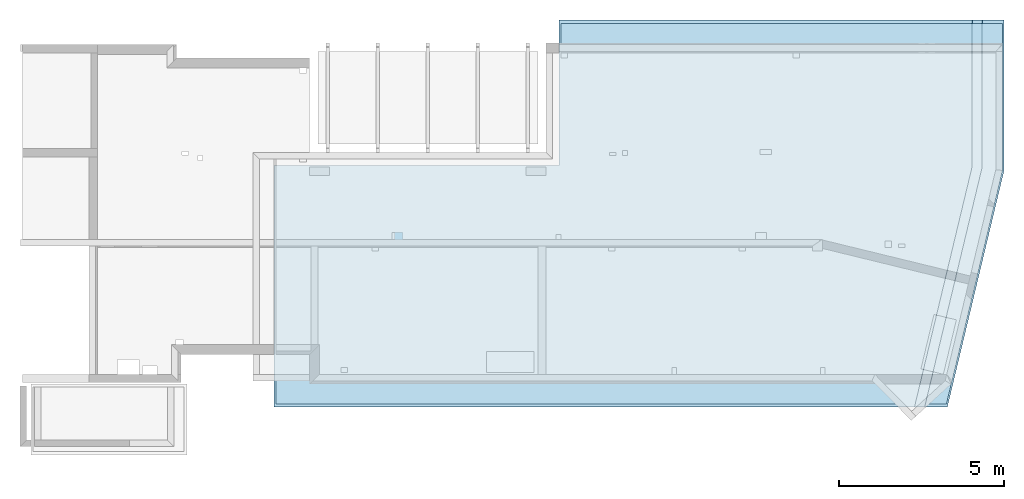
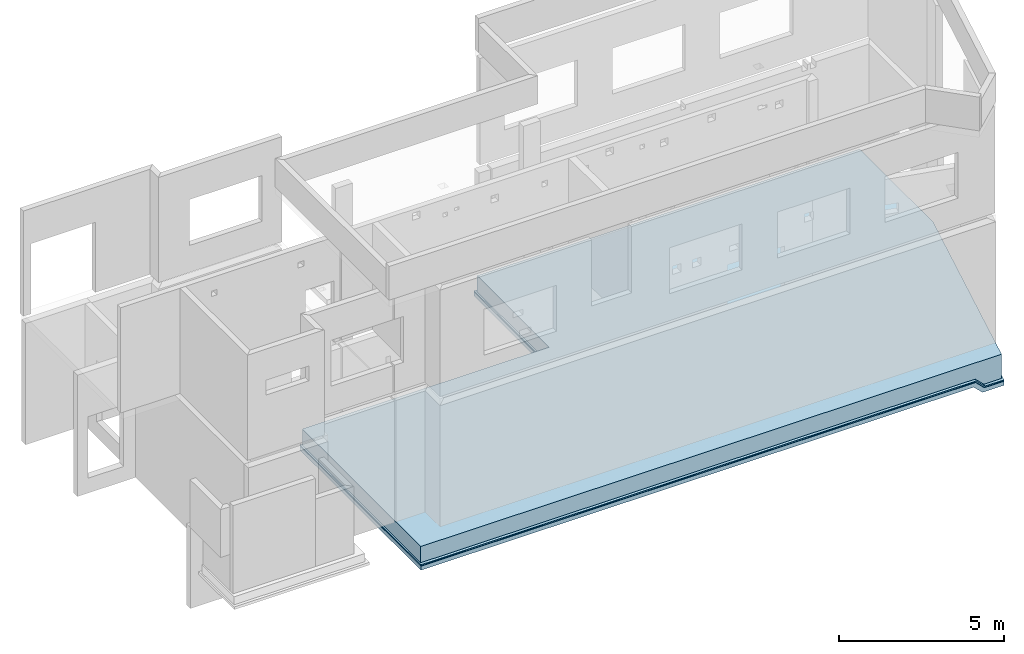
# One storey, part 7 of 7: 3 slabs.
"""IFC2X3 building model written with IfcOpenShell, lengths in millimetres."""

import ifcopenshell
import ifcopenshell.guid

model = None  # the IFC model being written
_history = None  # IfcOwnerHistory: only IFC2X3 demands one
_inside = {}  # id of a spatial element -> (the spatial element, [elements in it])
_under = {}  # id of a project, library or spatial element -> (it, [spatial elements below it])
_declared = {}  # id of a project -> (the project, [libraries it declares])
_typed = {}  # id of a type object -> (the type object, [elements of that type])
_made_of = {}  # id of a material, layer set ... -> (it, [elements and type objects made of it])


def new_model(schema):
    """Start an empty IFC model of exactly this schema.

    Asked for "IFC4X3", IfcOpenShell would pick the latest addendum, in which some entities
    have other attributes; the version numbers below select the first issue.
    IFC2X3 requires an IfcOwnerHistory on every rooted entity: one is made here for all.
    """
    global model, _history
    if schema == "IFC4X3":
        model = ifcopenshell.file(schema_version=(4, 3, 0, 0))
    else:
        model = ifcopenshell.file(schema=schema)
    _inside.clear()
    _under.clear()
    _declared.clear()
    _typed.clear()
    _made_of.clear()
    _history = None
    if model.schema == "IFC2X3":
        org = make("IfcOrganization", Name="unknown")
        user = make(
            "IfcPersonAndOrganization",
            ThePerson=make("IfcPerson", FamilyName="unknown"),
            TheOrganization=org,
        )
        app = make(
            "IfcApplication",
            ApplicationDeveloper=org,
            Version="unknown",
            ApplicationFullName="unknown",
            ApplicationIdentifier="unknown",
        )
        _history = make(
            "IfcOwnerHistory",
            OwningUser=user,
            OwningApplication=app,
            ChangeAction="ADDED",
            CreationDate=0,
        )
    return model


def make(cls, **values):
    """One entity of the class cls with the attributes given. An attribute that is None is left unset."""
    return model.create_entity(
        cls, **{name: value for name, value in values.items() if value is not None}
    )


def entity(cls, *values):
    """Any entity or typed value of the class cls, its attributes in the order of the schema. None: left unset."""
    e = model.create_entity(cls)
    for i, value in enumerate(values):
        if value is not None:
            e[i] = value
    return e


def rooted(cls, **values):
    """An entity with a GlobalId (a new one), such as an element, a storey or a relation."""
    return make(cls, GlobalId=ifcopenshell.guid.new(), OwnerHistory=_history, **values)


def si_unit(unit_type, name, prefix=None):
    """IfcSIUnit, for example si_unit("LENGTHUNIT", "METRE", prefix="MILLI")."""
    return make("IfcSIUnit", UnitType=unit_type, Prefix=prefix, Name=name)


def converted_unit(unit_type, name, factor, base, dimensions=None, offset=None):
    """IfcConversionBasedUnit, such as the inch: factor (a typed value) times the base unit."""
    return make(
        "IfcConversionBasedUnit"
        if offset is None
        else "IfcConversionBasedUnitWithOffset",
        ConversionOffset=offset,
        Dimensions=None
        if dimensions is None
        else entity("IfcDimensionalExponents", *dimensions),
        UnitType=unit_type,
        Name=name,
        ConversionFactor=make(
            "IfcMeasureWithUnit", ValueComponent=factor, UnitComponent=base
        ),
    )


def derived_unit(unit_type, elements):
    """IfcDerivedUnit: a product of units, each with its exponent."""
    return make(
        "IfcDerivedUnit",
        Elements=[
            make("IfcDerivedUnitElement", Unit=unit, Exponent=power)
            for unit, power in elements
        ],
        UnitType=unit_type,
    )


def money_unit(currency):
    """IfcMonetaryUnit."""
    return make("IfcMonetaryUnit", Currency=currency)


def assignment(units):
    """IfcUnitAssignment: the units of a project."""
    return None if units is None else make("IfcUnitAssignment", Units=units)


def point(xyz):
    """IfcCartesianPoint."""
    return None if xyz is None else make("IfcCartesianPoint", Coordinates=xyz)


def direction(xyz):
    """IfcDirection."""
    return None if xyz is None else make("IfcDirection", DirectionRatios=xyz)


def frame(location, z_axis=None, x_axis=None):
    """IfcAxis2Placement3D, a coordinate frame: its origin and axes. An axis left out is left unset."""
    return make(
        "IfcAxis2Placement3D",
        Location=point(location),
        Axis=direction(z_axis),
        RefDirection=direction(x_axis),
    )


def origin_with_axes():
    """The frame at (0, 0, 0) with the z axis (0, 0, 1) and the x axis (1, 0, 0) written out."""
    return frame((0.0, 0.0, 0.0), z_axis=(0.0, 0.0, 1.0), x_axis=(1.0, 0.0, 0.0))


def place(relative_to, where):
    """IfcLocalPlacement: puts the frame where relative to a parent placement (None: the world)."""
    return make(
        "IfcLocalPlacement", PlacementRelTo=relative_to, RelativePlacement=where
    )


def context(
    kind, dimensions, precision=None, world=None, true_north=None, identifier=None
):
    """IfcGeometricRepresentationContext, for example the 3D "Model" context."""
    return make(
        "IfcGeometricRepresentationContext",
        ContextIdentifier=identifier,
        ContextType=kind,
        CoordinateSpaceDimension=dimensions,
        Precision=precision,
        WorldCoordinateSystem=world,
        TrueNorth=true_north,
    )


def subcontext(parent, identifier, kind, view, scale=None):
    """IfcGeometricRepresentationSubContext, for example "Body" below "Model"."""
    return make(
        "IfcGeometricRepresentationSubContext",
        ContextIdentifier=identifier,
        ContextType=kind,
        ParentContext=parent,
        TargetScale=scale,
        TargetView=view,
    )


def project(units=None, contexts=None):
    """IfcProject with its units and contexts."""
    return rooted(
        "IfcProject",
        Name="project",
        RepresentationContexts=contexts,
        UnitsInContext=assignment(units),
    )


def spatial(cls, under=None, at=None, **own):
    """A site, building, storey or space (cls), placed at a placement, below another one or the project."""
    s = rooted(cls, ObjectPlacement=at, **own)
    if under is not None:
        _under.setdefault(under.id(), (under, []))[1].append(s)
    return s


def faces_of(points, faces, orient=None, outer=None):
    """IfcFace entities. A face is a list of loops; a loop is a list of indices into points, from 0.

    orient and outer hold one flag for each loop. By default every Orientation is true, the
    first loop of a face is its IfcFaceOuterBound and the others are IfcFaceBound.
    """
    made = []
    for i, loops in enumerate(faces):
        bounds = []
        for j, loop in enumerate(loops):
            is_outer = j == 0 if outer is None else outer[i][j]
            bounds.append(
                make(
                    "IfcFaceOuterBound" if is_outer else "IfcFaceBound",
                    Bound=make("IfcPolyLoop", Polygon=[points[k] for k in loop]),
                    Orientation=True if orient is None else orient[i][j],
                )
            )
        made.append(make("IfcFace", Bounds=bounds))
    return made


def faceted_brep(points, faces, orient=None, outer=None, voids=None):
    """IfcFacetedBrep: a solid bounded by flat faces; with voids (closed shells), ...WithVoids."""
    shared = [point(p) for p in points]
    hull = make("IfcClosedShell", CfsFaces=faces_of(shared, faces, orient, outer))
    if voids is None:
        return make("IfcFacetedBrep", Outer=hull)
    return make(
        "IfcFacetedBrepWithVoids",
        Outer=hull,
        Voids=[
            make(cls, CfsFaces=faces_of(shared, fs, o, b)) for cls, fs, o, b in voids
        ],
    )


def shape(context_of_items, identifier, shape_type, items):
    """IfcShapeRepresentation: the items that make up one representation, for example the "Body"."""
    return make(
        "IfcShapeRepresentation",
        ContextOfItems=context_of_items,
        RepresentationIdentifier=identifier,
        RepresentationType=shape_type,
        Items=items,
    )


def material(Name=None, Category=None):
    """IfcMaterial."""
    return make("IfcMaterial", Name=Name, Category=Category)


def made_of(thing, what):
    """Note that an element or type object is made of a material, layer set ...; save() writes the relation."""
    if what is not None:
        _made_of.setdefault(what.id(), (what, []))[1].append(thing)
    return thing


def type_object(cls, material=None, **own):
    """A type object (cls), such as IfcWallType, which elements share."""
    return made_of(rooted(cls, **own), material)


def element(
    cls,
    number,
    at=None,
    inside=None,
    cuts=None,
    type_object=None,
    material=None,
    context=None,
    identifier="Body",
    shape_type=None,
    held_by="IfcProductDefinitionShape",
    body=None,
    shapes=None,
    **own,
):
    """One element of the class cls, such as IfcWall. Its Tag is "e" and its number.

    at: its placement. inside: the storey or other place that contains it. cuts: it is an
    opening in that element (IfcRelVoidsElement). A single representation is given by context,
    identifier, shape_type and body (its items); several are given by shapes. held_by: the class
    of the entity that holds the representations. save() writes the other relations.
    """
    e = rooted(cls, Tag="e%d" % number, ObjectPlacement=at, **own)
    if body is not None:
        shapes = [shape(context, identifier, shape_type, body)]
    if shapes is not None:
        e.Representation = make(held_by, Representations=shapes)
    if inside is not None:
        _inside.setdefault(inside.id(), (inside, []))[1].append(e)
    if cuts is not None:
        rooted(
            "IfcRelVoidsElement", RelatingBuildingElement=cuts, RelatedOpeningElement=e
        )
    if type_object is not None:
        _typed.setdefault(type_object.id(), (type_object, []))[1].append(e)
    return made_of(e, material)


def aggregate(whole, parts):
    """IfcRelAggregates: a whole, such as a stair, and the parts it consists of."""
    return rooted("IfcRelAggregates", RelatingObject=whole, RelatedObjects=parts)


def save(model, path):
    """Write the relations noted so far, then the file.

    IfcRelAggregates (storeys below a building ...), IfcRelContainedInSpatialStructure (elements
    in a storey), IfcRelDefinesByType, IfcRelAssociatesMaterial and IfcRelDeclares: one each for
    every whole, place, type object, material and project.
    """
    for whole, parts in _under.values():
        aggregate(whole, parts)
    for where, things in _inside.values():
        rooted(
            "IfcRelContainedInSpatialStructure",
            RelatedElements=things,
            RelatingStructure=where,
        )
    for kind, things in _typed.values():
        rooted("IfcRelDefinesByType", RelatedObjects=things, RelatingType=kind)
    for what, things in _made_of.values():
        rooted("IfcRelAssociatesMaterial", RelatedObjects=things, RelatingMaterial=what)
    for by, libraries in _declared.values():
        rooted("IfcRelDeclares", RelatingContext=by, RelatedDefinitions=libraries)
    model.write(path)


model = new_model("IFC2X3")

# Units and contexts
model_context = context("Model", 3, precision=1e-05, world=origin_with_axes(), true_north=direction((0.0, 1.0)))
body_context = subcontext(model_context, "Body", "Model", "MODEL_VIEW", scale=1.0)
ifc_project = project(units=[si_unit("LENGTHUNIT", "METRE", prefix="MILLI"), si_unit("AREAUNIT", "SQUARE_METRE"), si_unit("VOLUMEUNIT", "CUBIC_METRE"), si_unit("ABSORBEDDOSEUNIT", "GRAY"), si_unit("AMOUNTOFSUBSTANCEUNIT", "MOLE"), si_unit("DOSEEQUIVALENTUNIT", "SIEVERT"), si_unit("ELECTRICCAPACITANCEUNIT", "FARAD"), si_unit("ELECTRICCHARGEUNIT", "COULOMB"), si_unit("ELECTRICCONDUCTANCEUNIT", "SIEMENS"), si_unit("ELECTRICCURRENTUNIT", "AMPERE"), si_unit("ELECTRICRESISTANCEUNIT", "OHM"), si_unit("ELECTRICVOLTAGEUNIT", "VOLT"), si_unit("ENERGYUNIT", "JOULE"), si_unit("FORCEUNIT", "NEWTON"), si_unit("FREQUENCYUNIT", "HERTZ"), si_unit("ILLUMINANCEUNIT", "LUX"), si_unit("INDUCTANCEUNIT", "HENRY"), si_unit("LUMINOUSFLUXUNIT", "LUMEN"), si_unit("LUMINOUSINTENSITYUNIT", "CANDELA"), si_unit("MAGNETICFLUXDENSITYUNIT", "TESLA"), si_unit("MAGNETICFLUXUNIT", "WEBER"), si_unit("MASSUNIT", "GRAM"), converted_unit("PLANEANGLEUNIT", "degree", entity("IfcReal", 0.0174532925199433), si_unit("PLANEANGLEUNIT", "RADIAN"), dimensions=[0, 0, 0, 0, 0, 0, 0]), si_unit("POWERUNIT", "WATT"), si_unit("PRESSUREUNIT", "PASCAL"), si_unit("RADIOACTIVITYUNIT", "BECQUEREL"), si_unit("SOLIDANGLEUNIT", "STERADIAN"), si_unit("THERMODYNAMICTEMPERATUREUNIT", "KELVIN"), si_unit("TIMEUNIT", "SECOND"), derived_unit("ACCELERATIONUNIT", [(si_unit("LENGTHUNIT", "METRE", prefix="MILLI"), 1), (si_unit("TIMEUNIT", "SECOND"), -2)]), derived_unit("ANGULARVELOCITYUNIT", [(converted_unit("PLANEANGLEUNIT", "degree", entity("IfcReal", 0.0174532925199433), si_unit("PLANEANGLEUNIT", "RADIAN"), dimensions=[0, 0, 0, 0, 0, 0, 0]), 1), (si_unit("TIMEUNIT", "SECOND"), -1)]), derived_unit("CURVATUREUNIT", [(converted_unit("PLANEANGLEUNIT", "degree", entity("IfcReal", 0.0174532925199433), si_unit("PLANEANGLEUNIT", "RADIAN"), dimensions=[0, 0, 0, 0, 0, 0, 0]), 1), (si_unit("LENGTHUNIT", "METRE", prefix="MILLI"), -1)]), derived_unit("DYNAMICVISCOSITYUNIT", [(si_unit("PRESSUREUNIT", "PASCAL"), 1), (si_unit("TIMEUNIT", "SECOND"), 1)]), derived_unit("HEATFLUXDENSITYUNIT", [(si_unit("POWERUNIT", "WATT"), 1), (si_unit("LENGTHUNIT", "METRE", prefix="MILLI"), -2)]), derived_unit("HEATINGVALUEUNIT", [(si_unit("ENERGYUNIT", "JOULE"), 1), (si_unit("MASSUNIT", "GRAM"), -1)]), derived_unit("INTEGERCOUNTRATEUNIT", [(si_unit("TIMEUNIT", "SECOND"), -1)]), derived_unit("IONCONCENTRATIONUNIT", [(si_unit("MASSUNIT", "GRAM"), 1), (si_unit("VOLUMEUNIT", "CUBIC_METRE"), -1)]), derived_unit("ISOTHERMALMOISTURECAPACITYUNIT", [(si_unit("VOLUMEUNIT", "CUBIC_METRE"), 1), (si_unit("MASSUNIT", "GRAM"), -1)]), derived_unit("KINEMATICVISCOSITYUNIT", [(si_unit("AREAUNIT", "SQUARE_METRE"), 1), (si_unit("TIMEUNIT", "SECOND"), -1)]), derived_unit("LINEARFORCEUNIT", [(si_unit("FORCEUNIT", "NEWTON"), 1), (si_unit("LENGTHUNIT", "METRE", prefix="MILLI"), -1)]), derived_unit("LINEARMOMENTUNIT", [(si_unit("FORCEUNIT", "NEWTON"), 1), (si_unit("LENGTHUNIT", "METRE", prefix="MILLI"), -1)]), derived_unit("LINEARSTIFFNESSUNIT", [(si_unit("FORCEUNIT", "NEWTON"), 1), (si_unit("LENGTHUNIT", "METRE", prefix="MILLI"), -1)]), derived_unit("LINEARVELOCITYUNIT", [(si_unit("LENGTHUNIT", "METRE", prefix="MILLI"), 1), (si_unit("TIMEUNIT", "SECOND"), -1)]), derived_unit("LUMINOUSINTENSITYDISTRIBUTIONUNIT", [(si_unit("LUMINOUSINTENSITYUNIT", "CANDELA"), 1), (si_unit("LUMINOUSFLUXUNIT", "LUMEN"), -1)]), derived_unit("MASSDENSITYUNIT", [(si_unit("MASSUNIT", "GRAM"), 1), (si_unit("VOLUMEUNIT", "CUBIC_METRE"), -1)]), derived_unit("MASSFLOWRATEUNIT", [(si_unit("MASSUNIT", "GRAM"), 1), (si_unit("TIMEUNIT", "SECOND"), -1)]), derived_unit("MASSPERLENGTHUNIT", [(si_unit("MASSUNIT", "GRAM"), 1), (si_unit("LENGTHUNIT", "METRE", prefix="MILLI"), -1)]), derived_unit("MODULUSOFELASTICITYUNIT", [(si_unit("FORCEUNIT", "NEWTON"), 1), (si_unit("AREAUNIT", "SQUARE_METRE"), -1)]), derived_unit("MODULUSOFLINEARSUBGRADEREACTIONUNIT", [(si_unit("FORCEUNIT", "NEWTON"), 1), (si_unit("LENGTHUNIT", "METRE", prefix="MILLI"), -2)]), derived_unit("MODULUSOFROTATIONALSUBGRADEREACTIONUNIT", [(si_unit("FORCEUNIT", "NEWTON"), 1), (si_unit("LENGTHUNIT", "METRE", prefix="MILLI"), 1)]), derived_unit("MODULUSOFSUBGRADEREACTIONUNIT", [(si_unit("FORCEUNIT", "NEWTON"), 1), (si_unit("VOLUMEUNIT", "CUBIC_METRE"), -1)]), derived_unit("MOISTUREDIFFUSIVITYUNIT", [(si_unit("VOLUMEUNIT", "CUBIC_METRE"), 1), (si_unit("TIMEUNIT", "SECOND"), -1)]), derived_unit("MOLECULARWEIGHTUNIT", [(si_unit("MASSUNIT", "GRAM"), 1), (si_unit("AMOUNTOFSUBSTANCEUNIT", "MOLE"), -1)]), derived_unit("PLANARFORCEUNIT", [(si_unit("FORCEUNIT", "NEWTON"), 1), (si_unit("LENGTHUNIT", "METRE", prefix="MILLI"), -2)]), derived_unit("ROTATIONALFREQUENCYUNIT", [(si_unit("TIMEUNIT", "SECOND"), -1)]), derived_unit("ROTATIONALMASSUNIT", [(si_unit("MASSUNIT", "GRAM"), 1), (si_unit("LENGTHUNIT", "METRE", prefix="MILLI"), 2)]), derived_unit("ROTATIONALSTIFFNESSUNIT", [(si_unit("FORCEUNIT", "NEWTON"), 1), (si_unit("LENGTHUNIT", "METRE", prefix="MILLI"), 1), (converted_unit("PLANEANGLEUNIT", "degree", entity("IfcReal", 0.0174532925199433), si_unit("PLANEANGLEUNIT", "RADIAN"), dimensions=[0, 0, 0, 0, 0, 0, 0]), -1)]), derived_unit("SECTIONAREAINTEGRALUNIT", [(si_unit("LENGTHUNIT", "METRE", prefix="MILLI"), 5)]), derived_unit("SECTIONMODULUSUNIT", [(si_unit("LENGTHUNIT", "METRE", prefix="MILLI"), 3)]), derived_unit("SHEARMODULUSUNIT", [(si_unit("FORCEUNIT", "NEWTON"), 1), (si_unit("AREAUNIT", "SQUARE_METRE"), -1)]), derived_unit("SOUNDPOWERUNIT", [(si_unit("ENERGYUNIT", "JOULE"), 1), (si_unit("TIMEUNIT", "SECOND"), -1)]), derived_unit("SPECIFICHEATCAPACITYUNIT", [(si_unit("FORCEUNIT", "NEWTON"), 1), (si_unit("MASSUNIT", "GRAM"), -1), (si_unit("THERMODYNAMICTEMPERATUREUNIT", "KELVIN"), -1)]), derived_unit("TEMPERATUREGRADIENTUNIT", [(si_unit("THERMODYNAMICTEMPERATUREUNIT", "KELVIN"), 1), (si_unit("LENGTHUNIT", "METRE", prefix="MILLI"), -1)]), derived_unit("THERMALADMITTANCEUNIT", [(si_unit("POWERUNIT", "WATT"), 1), (si_unit("AREAUNIT", "SQUARE_METRE"), -1), (si_unit("THERMODYNAMICTEMPERATUREUNIT", "KELVIN"), -1)]), derived_unit("THERMALCONDUCTANCEUNIT", [(si_unit("POWERUNIT", "WATT"), 1), (si_unit("LENGTHUNIT", "METRE", prefix="MILLI"), -1), (si_unit("THERMODYNAMICTEMPERATUREUNIT", "KELVIN"), -1)]), derived_unit("THERMALEXPANSIONCOEFFICIENTUNIT", [(si_unit("THERMODYNAMICTEMPERATUREUNIT", "KELVIN"), -1)]), derived_unit("THERMALRESISTANCEUNIT", [(si_unit("AREAUNIT", "SQUARE_METRE"), 1), (si_unit("POWERUNIT", "WATT"), -1)]), derived_unit("THERMALTRANSMITTANCEUNIT", [(si_unit("POWERUNIT", "WATT"), 1), (si_unit("AREAUNIT", "SQUARE_METRE"), -1), (si_unit("THERMODYNAMICTEMPERATUREUNIT", "KELVIN"), -1)]), derived_unit("TORQUEUNIT", [(si_unit("FORCEUNIT", "NEWTON"), 1), (si_unit("LENGTHUNIT", "METRE", prefix="MILLI"), 1)]), derived_unit("VAPORPERMEABILITYUNIT", [(si_unit("MASSUNIT", "GRAM"), 1), (si_unit("TIMEUNIT", "SECOND"), -1)]), derived_unit("VOLUMETRICFLOWRATEUNIT", [(si_unit("VOLUMEUNIT", "CUBIC_METRE"), 1), (si_unit("TIMEUNIT", "SECOND"), -1)]), derived_unit("WARPINGCONSTANTUNIT", [(si_unit("LENGTHUNIT", "METRE", prefix="MILLI"), 6)]), derived_unit("WARPINGMOMENTUNIT", [(si_unit("FORCEUNIT", "NEWTON"), 1), (si_unit("LENGTHUNIT", "METRE", prefix="MILLI"), 2)]), money_unit("USD")], contexts=[model_context])

# Site, building, storey
site_placement = place(None, origin_with_axes())
site = spatial("IfcSite", under=ifc_project, at=site_placement, CompositionType="ELEMENT")
building_placement = place(site_placement, origin_with_axes())
building = spatial("IfcBuilding", under=site, at=building_placement, Name="1", CompositionType="ELEMENT")
storey_placement = place(building_placement, frame((0.0, 0.0, -4900.0), z_axis=(0.0, 0.0, 1.0), x_axis=(1.0, 0.0, 0.0)))
storey = spatial("IfcBuildingStorey", under=building, at=storey_placement, CompositionType="ELEMENT", Elevation=-4900.0)

# Slabs
ifc_material_1 = material()
slab_type_1 = type_object("IfcSlabType", PredefinedType="NOTDEFINED")
slab_1_placement = place(storey_placement, frame((16555.0, 10760.0, -600.0), z_axis=(0.0, 0.0, -1.0), x_axis=(1.0, 0.0, 0.0)))
element("IfcSlab", 1, at=slab_1_placement, inside=storey, type_object=slab_type_1, material=ifc_material_1, context=body_context, shape_type="Brep", body=[
    faceted_brep([(12844.0, 0.0, 300.0), (12844.0, 0.0, 340.0), (12544.0, 0.0, 40.0), (12560.0, 0.0, 40.0), (12560.0, 0.0, 0.0), (12860.0, 0.0, 300.0), (11119.016066, 11760.0, 300.0), (10810.512815, 11760.0, 0.0), (10810.512815, 11760.0, 40.0), (10794.059308, 11760.0, 40.0), (11102.562559, 11760.0, 340.0), (11102.562559, 11760.0, 300.0), (12504.0, 4456.989465, 0.0), (10752.925542, 11760.0, 0.0), (12560.0, 4463.609329, 0.0), (12504.0, 0.0, 0.0), (0.0, 0.0, 0.0), (0.0, 4420.0, 0.0), (-8655.0, 4420.0, 0.0), (-8655.0, 11760.0, 0.0), (0.0, 0.0, 40.0), (0.0, 4420.0, 40.0), (-8655.0, 11760.0, 40.0), (-8655.0, 4420.0, 40.0), (12544.0, 4461.717939, 40.0), (12860.0, 0.0, 340.0), (11119.016066, 11760.0, 340.0), (12844.0, 4497.181496, 340.0), (12860.0, 4499.072886, 340.0), (12860.0, 4499.072886, 300.0), (13510.0, 0.0, 340.0), (13510.0, 4575.910593, 340.0), (11787.439775, 11760.0, 340.0), (11787.439775, 11760.0, 300.0), (13510.0, 0.0, 300.0), (13510.0, 4575.910593, 300.0)], [[[0, 1, 2, 3, 4, 5]], [[6, 7, 8, 9, 10, 11]], [[12, 13, 7, 14, 4, 15]], [[15, 4, 3, 2]], [[9, 8, 7, 13]], [[12, 15, 16, 17, 18, 19, 13]], [[20, 21, 17, 16]], [[15, 2, 20, 16]], [[9, 13, 19, 22]], [[23, 22, 19, 18]], [[21, 23, 18, 17]], [[2, 24, 9, 22, 23, 21, 20]], [[0, 5, 25, 1]], [[6, 11, 10, 26]], [[2, 1, 27, 24]], [[24, 27, 10, 9]], [[10, 27, 1, 25, 28, 26]], [[14, 29, 5, 4]], [[14, 7, 6, 29]], [[28, 25, 30, 31, 32, 26]], [[6, 26, 32, 33]], [[25, 5, 34, 30]], [[29, 6, 33, 35, 34, 5]], [[31, 30, 34, 35]], [[32, 31, 35, 33]]]),
])
slab_2_placement = place(storey_placement, frame((7900.0, 6340.0, -650.0), z_axis=(0.0, 0.0, -1.0), x_axis=(1.0, 0.0, 0.0)))
element("IfcSlab", 2, at=slab_2_placement, inside=storey, type_object=slab_type_1, material=ifc_material_1, context=body_context, shape_type="Brep", body=[
    faceted_brep([(21432.72583, -4420.0, 450.0), (21132.72583, -4420.0, 150.0), (21194.85, -4420.0, 150.0), (21194.85, -4420.0, 0.0), (21194.857864, -4420.0, 0.0), (21494.857864, -4420.0, 300.0), (21432.72583, -4420.0, 300.0), (19753.303018, 7340.0, 300.0), (19444.799767, 7340.0, 0.0), (19444.79168, 7340.0, 0.0), (19444.79168, 7340.0, 150.0), (19380.906652, 7340.0, 150.0), (19689.409903, 7340.0, 450.0), (19689.409903, 7340.0, 300.0), (20982.72583, -4420.0, 0.0), (20982.72583, 16.151768, 0.0), (19226.655027, 7340.0, 0.0), (21194.85, 41.22736, 0.0), (8655.0, -4420.0, 150.0), (8655.0, 0.0, 150.0), (8655.0, 0.0, 0.0), (8655.0, -4420.0, 0.0), (0.0, 0.0, 150.0), (0.0, 0.0, 0.0), (0.0, 7340.0, 0.0), (21132.72583, 33.883547, 150.0), (0.0, 7340.0, 150.0), (21494.857864, -4420.0, 450.0), (19753.303018, 7340.0, 450.0), (21432.72583, 69.347104, 450.0), (21194.857864, 41.22829, 0.0), (21494.857864, 76.691847, 450.0), (21494.857864, 76.691847, 300.0), (22165.0, -4420.0, 450.0), (22165.0, 155.910593, 450.0), (20442.439775, 7340.0, 450.0), (22165.0, -4420.0, 300.0), (20442.439775, 7340.0, 300.0), (22165.0, 155.910593, 300.0)], [[[0, 1, 2, 3, 4, 5, 6]], [[7, 8, 9, 10, 11, 12, 13]], [[14, 3, 2, 1]], [[15, 16, 9, 17, 3, 14]], [[11, 10, 9, 16]], [[18, 19, 20, 21]], [[14, 1, 18, 21]], [[19, 22, 23, 20]], [[15, 14, 21, 20, 23, 24, 16]], [[1, 25, 11, 26, 22, 19, 18]], [[22, 26, 24, 23]], [[11, 16, 24, 26]], [[0, 6, 5, 27]], [[7, 13, 12, 28]], [[1, 0, 29, 25]], [[3, 17, 9, 8, 30, 4]], [[25, 29, 12, 11]], [[12, 29, 0, 27, 31, 28]], [[30, 32, 5, 4]], [[30, 8, 7, 32]], [[31, 27, 33, 34, 35, 28]], [[27, 5, 36, 33]], [[7, 28, 35, 37]], [[34, 33, 36, 38]], [[32, 7, 37, 38, 36, 5]], [[35, 34, 38, 37]]]),
])
ifc_material_2 = material()
slab_type_2 = type_object("IfcSlabType", PredefinedType="NOTDEFINED")
slab_3_placement = place(storey_placement, frame((7950.0, 6290.0, 0.0), z_axis=(0.0, 0.0, -1.0), x_axis=(1.0, 0.0, 0.0)))
element("IfcSlab", 3, at=slab_3_placement, inside=storey, type_object=slab_type_2, material=ifc_material_2, context=body_context, shape_type="Brep", body=[
    faceted_brep([(21165.0, -6.390671, 600.0), (19439.490248, 7190.0, 600.0), (0.0, 7190.0, 600.0), (0.0, 0.0, 600.0), (8655.0, 0.0, 600.0), (8655.0, -4370.0, 600.0), (21165.0, -4370.0, 600.0), (0.0, 0.0, 0.0), (0.0, 7190.0, 0.0), (20365.0, 7190.0, 0.0), (22065.0, 100.0, 0.0), (22065.0, -4370.0, 0.0), (8655.0, -4370.0, 0.0), (8655.0, 0.0, 0.0), (22065.0, -4370.0, 600.0), (22065.0, 100.0, 600.0), (20365.0, 7190.0, 600.0), (21465.0, -4370.0, 900.0), (22065.0, -4370.0, 900.0), (22065.0, 100.0, 900.0), (20365.0, 7190.0, 900.0), (19747.993499, 7190.0, 900.0), (21465.0, 29.072886, 900.0)], [[[0, 1, 2, 3, 4, 5, 6]], [[7, 8, 9, 10, 11, 12, 13]], [[3, 2, 8, 7]], [[4, 3, 7, 13]], [[5, 4, 13, 12]], [[14, 6, 5, 12, 11]], [[15, 14, 11, 10]], [[16, 15, 10, 9]], [[2, 1, 16, 9, 8]], [[17, 6, 14, 18]], [[19, 18, 14, 15]], [[20, 19, 15, 16]], [[1, 21, 20, 16]], [[22, 17, 18, 19, 20, 21]], [[0, 22, 21, 1]], [[17, 22, 0, 6]]]),
])

save(model, "model.ifc")
